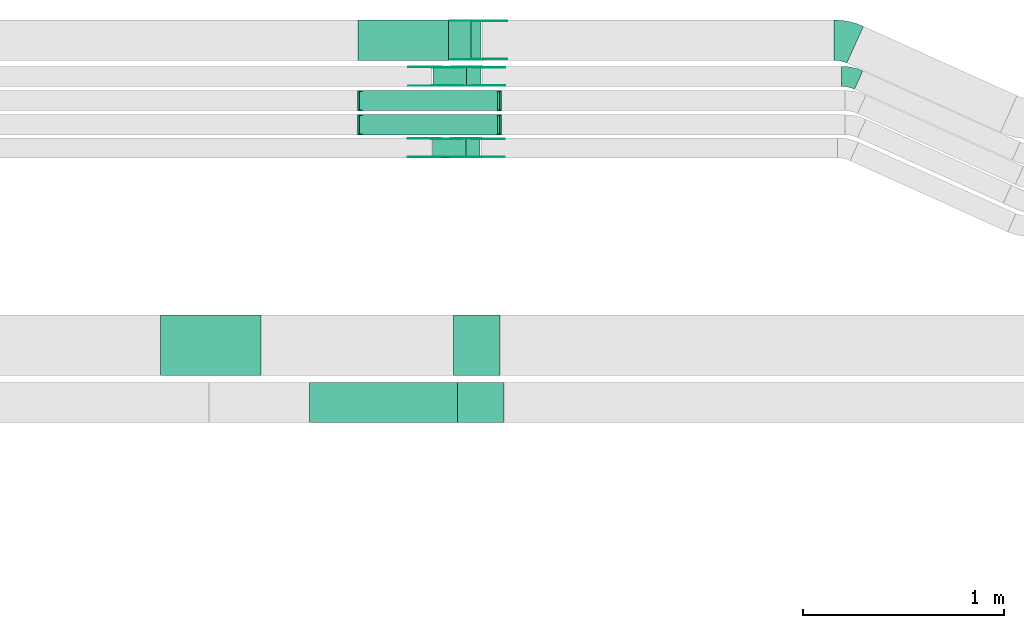
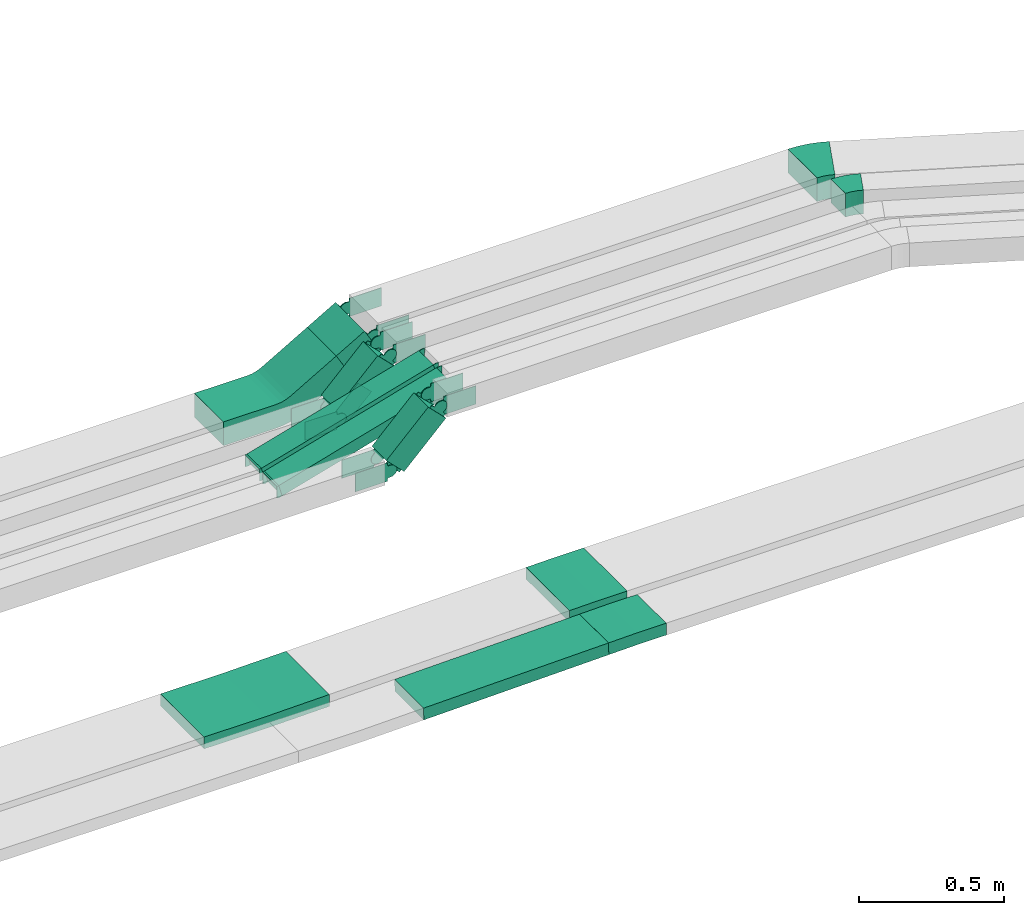
# One storey, part 11 of 28: 30 flow fittings, 6 flow segments.
"""IFC2X3 building model written with IfcOpenShell, lengths in millimetres."""

import ifcopenshell
import ifcopenshell.guid

model = None  # the IFC model being written
_history = None  # IfcOwnerHistory: only IFC2X3 demands one
_inside = {}  # id of a spatial element -> (the spatial element, [elements in it])
_under = {}  # id of a project, library or spatial element -> (it, [spatial elements below it])
_declared = {}  # id of a project -> (the project, [libraries it declares])
_typed = {}  # id of a type object -> (the type object, [elements of that type])
_made_of = {}  # id of a material, layer set ... -> (it, [elements and type objects made of it])


def new_model(schema):
    """Start an empty IFC model of exactly this schema.

    Asked for "IFC4X3", IfcOpenShell would pick the latest addendum, in which some entities
    have other attributes; the version numbers below select the first issue.
    IFC2X3 requires an IfcOwnerHistory on every rooted entity: one is made here for all.
    """
    global model, _history
    if schema == "IFC4X3":
        model = ifcopenshell.file(schema_version=(4, 3, 0, 0))
    else:
        model = ifcopenshell.file(schema=schema)
    _inside.clear()
    _under.clear()
    _declared.clear()
    _typed.clear()
    _made_of.clear()
    _history = None
    if model.schema == "IFC2X3":
        org = make("IfcOrganization", Name="unknown")
        user = make(
            "IfcPersonAndOrganization",
            ThePerson=make("IfcPerson", FamilyName="unknown"),
            TheOrganization=org,
        )
        app = make(
            "IfcApplication",
            ApplicationDeveloper=org,
            Version="unknown",
            ApplicationFullName="unknown",
            ApplicationIdentifier="unknown",
        )
        _history = make(
            "IfcOwnerHistory",
            OwningUser=user,
            OwningApplication=app,
            ChangeAction="ADDED",
            CreationDate=0,
        )
    return model


def make(cls, **values):
    """One entity of the class cls with the attributes given. An attribute that is None is left unset."""
    return model.create_entity(
        cls, **{name: value for name, value in values.items() if value is not None}
    )


def entity(cls, *values):
    """Any entity or typed value of the class cls, its attributes in the order of the schema. None: left unset."""
    e = model.create_entity(cls)
    for i, value in enumerate(values):
        if value is not None:
            e[i] = value
    return e


def rooted(cls, **values):
    """An entity with a GlobalId (a new one), such as an element, a storey or a relation."""
    return make(cls, GlobalId=ifcopenshell.guid.new(), OwnerHistory=_history, **values)


def si_unit(unit_type, name, prefix=None):
    """IfcSIUnit, for example si_unit("LENGTHUNIT", "METRE", prefix="MILLI")."""
    return make("IfcSIUnit", UnitType=unit_type, Prefix=prefix, Name=name)


def converted_unit(unit_type, name, factor, base, dimensions=None, offset=None):
    """IfcConversionBasedUnit, such as the inch: factor (a typed value) times the base unit."""
    return make(
        "IfcConversionBasedUnit"
        if offset is None
        else "IfcConversionBasedUnitWithOffset",
        ConversionOffset=offset,
        Dimensions=None
        if dimensions is None
        else entity("IfcDimensionalExponents", *dimensions),
        UnitType=unit_type,
        Name=name,
        ConversionFactor=make(
            "IfcMeasureWithUnit", ValueComponent=factor, UnitComponent=base
        ),
    )


def derived_unit(unit_type, elements):
    """IfcDerivedUnit: a product of units, each with its exponent."""
    return make(
        "IfcDerivedUnit",
        Elements=[
            make("IfcDerivedUnitElement", Unit=unit, Exponent=power)
            for unit, power in elements
        ],
        UnitType=unit_type,
    )


def assignment(units):
    """IfcUnitAssignment: the units of a project."""
    return None if units is None else make("IfcUnitAssignment", Units=units)


def point(xyz):
    """IfcCartesianPoint."""
    return None if xyz is None else make("IfcCartesianPoint", Coordinates=xyz)


def direction(xyz):
    """IfcDirection."""
    return None if xyz is None else make("IfcDirection", DirectionRatios=xyz)


def frame(location, z_axis=None, x_axis=None):
    """IfcAxis2Placement3D, a coordinate frame: its origin and axes. An axis left out is left unset."""
    return make(
        "IfcAxis2Placement3D",
        Location=point(location),
        Axis=direction(z_axis),
        RefDirection=direction(x_axis),
    )


def frame_2d(location, x_axis=None):
    """IfcAxis2Placement2D, a coordinate frame in the plane: its origin and x axis."""
    return make(
        "IfcAxis2Placement2D", Location=point(location), RefDirection=direction(x_axis)
    )


def origin():
    """The frame at (0, 0, 0) with its axes left unset."""
    return frame((0.0, 0.0, 0.0))


def origin_2d_with_axis():
    """The frame at (0, 0) in the plane with the x axis (1, 0) written out."""
    return frame_2d((0.0, 0.0), x_axis=(1.0, 0.0))


def place(relative_to, where):
    """IfcLocalPlacement: puts the frame where relative to a parent placement (None: the world)."""
    return make(
        "IfcLocalPlacement", PlacementRelTo=relative_to, RelativePlacement=where
    )


def context(
    kind, dimensions, precision=None, world=None, true_north=None, identifier=None
):
    """IfcGeometricRepresentationContext, for example the 3D "Model" context."""
    return make(
        "IfcGeometricRepresentationContext",
        ContextIdentifier=identifier,
        ContextType=kind,
        CoordinateSpaceDimension=dimensions,
        Precision=precision,
        WorldCoordinateSystem=world,
        TrueNorth=true_north,
    )


def subcontext(parent, identifier, kind, view, scale=None):
    """IfcGeometricRepresentationSubContext, for example "Body" below "Model"."""
    return make(
        "IfcGeometricRepresentationSubContext",
        ContextIdentifier=identifier,
        ContextType=kind,
        ParentContext=parent,
        TargetScale=scale,
        TargetView=view,
    )


def project(units=None, contexts=None):
    """IfcProject with its units and contexts."""
    return rooted(
        "IfcProject",
        Name="project",
        RepresentationContexts=contexts,
        UnitsInContext=assignment(units),
    )


def spatial(cls, under=None, at=None, **own):
    """A site, building, storey or space (cls), placed at a placement, below another one or the project."""
    s = rooted(cls, ObjectPlacement=at, **own)
    if under is not None:
        _under.setdefault(under.id(), (under, []))[1].append(s)
    return s


def polyline(points):
    """IfcPolyline through the points."""
    return make("IfcPolyline", Points=[point(p) for p in points])


def circle_curve(where, radius):
    """IfcCircle in the frame where."""
    return make("IfcCircle", Position=where, Radius=radius)


def parameter(value):
    """IfcParameterValue: where a trimmed curve begins or ends, as a parameter of its basis curve."""
    return model.create_entity("IfcParameterValue", value)


def trimmed(basis, trim1, trim2, sense, master):
    """IfcTrimmedCurve: the piece of a basis curve between two trims."""
    return make(
        "IfcTrimmedCurve",
        BasisCurve=basis,
        Trim1=trim1,
        Trim2=trim2,
        SenseAgreement=sense,
        MasterRepresentation=master,
    )


def segment(curve, same_sense, transition):
    """IfcCompositeCurveSegment."""
    return make(
        "IfcCompositeCurveSegment",
        Transition=transition,
        SameSense=same_sense,
        ParentCurve=curve,
    )


def composite_curve(segments, self_intersect=None):
    """IfcCompositeCurve: segments joined end to end."""
    return make("IfcCompositeCurve", Segments=segments, SelfIntersect=self_intersect)


def profile(cls, at=None, kind="AREA", **sizes):
    """A parametric profile (cls). Its sizes go by their IFC names, for example OverallWidth=200.0."""
    return make(cls, ProfileType=kind, Position=at, **sizes)


def rectangle(**sizes):
    """IfcRectangleProfileDef."""
    return profile("IfcRectangleProfileDef", **sizes)


def outline(outer, holes=None, kind="AREA"):
    """IfcArbitraryClosedProfileDef: a profile drawn as a closed curve; with holes, ...WithVoids."""
    if holes is None:
        return make("IfcArbitraryClosedProfileDef", ProfileType=kind, OuterCurve=outer)
    return make(
        "IfcArbitraryProfileDefWithVoids",
        ProfileType=kind,
        OuterCurve=outer,
        InnerCurves=holes,
    )


def extrude(swept, where, along, depth):
    """IfcExtrudedAreaSolid: the profile swept, set in the frame where, extruded along a direction by depth."""
    return make(
        "IfcExtrudedAreaSolid",
        SweptArea=swept,
        Position=where,
        ExtrudedDirection=direction(along),
        Depth=depth,
    )


def faces_of(points, faces, orient=None, outer=None):
    """IfcFace entities. A face is a list of loops; a loop is a list of indices into points, from 0.

    orient and outer hold one flag for each loop. By default every Orientation is true, the
    first loop of a face is its IfcFaceOuterBound and the others are IfcFaceBound.
    """
    made = []
    for i, loops in enumerate(faces):
        bounds = []
        for j, loop in enumerate(loops):
            is_outer = j == 0 if outer is None else outer[i][j]
            bounds.append(
                make(
                    "IfcFaceOuterBound" if is_outer else "IfcFaceBound",
                    Bound=make("IfcPolyLoop", Polygon=[points[k] for k in loop]),
                    Orientation=True if orient is None else orient[i][j],
                )
            )
        made.append(make("IfcFace", Bounds=bounds))
    return made


def faceted_brep(points, faces, orient=None, outer=None, voids=None):
    """IfcFacetedBrep: a solid bounded by flat faces; with voids (closed shells), ...WithVoids."""
    shared = [point(p) for p in points]
    hull = make("IfcClosedShell", CfsFaces=faces_of(shared, faces, orient, outer))
    if voids is None:
        return make("IfcFacetedBrep", Outer=hull)
    return make(
        "IfcFacetedBrepWithVoids",
        Outer=hull,
        Voids=[
            make(cls, CfsFaces=faces_of(shared, fs, o, b)) for cls, fs, o, b in voids
        ],
    )


def shape(context_of_items, identifier, shape_type, items):
    """IfcShapeRepresentation: the items that make up one representation, for example the "Body"."""
    return make(
        "IfcShapeRepresentation",
        ContextOfItems=context_of_items,
        RepresentationIdentifier=identifier,
        RepresentationType=shape_type,
        Items=items,
    )


def source(mapping_origin, context_of_items, identifier, shape_type, items):
    """IfcRepresentationMap: a shape defined once, which mapped items show again and again."""
    return make(
        "IfcRepresentationMap",
        MappingOrigin=mapping_origin,
        MappedRepresentation=shape(context_of_items, identifier, shape_type, items),
    )


def transform(
    local_origin,
    x_axis=None,
    y_axis=None,
    z_axis=None,
    scale=None,
    scale2=None,
    scale3=None,
    uniform=True,
):
    """IfcCartesianTransformationOperator3D, or its non-uniform kind. x_axis, y_axis, z_axis: its Axis1, 2, 3."""
    if uniform:
        return make(
            "IfcCartesianTransformationOperator3D",
            Axis1=direction(x_axis),
            Axis2=direction(y_axis),
            LocalOrigin=point(local_origin),
            Scale=scale,
            Axis3=direction(z_axis),
        )
    return make(
        "IfcCartesianTransformationOperator3DnonUniform",
        Axis1=direction(x_axis),
        Axis2=direction(y_axis),
        LocalOrigin=point(local_origin),
        Scale=scale,
        Axis3=direction(z_axis),
        Scale2=scale2,
        Scale3=scale3,
    )


def mapped(mapping_source, mapping_target):
    """IfcMappedItem: shows the shape of a source again, moved by a transform."""
    return make(
        "IfcMappedItem", MappingSource=mapping_source, MappingTarget=mapping_target
    )


def material(Name=None, Category=None):
    """IfcMaterial."""
    return make("IfcMaterial", Name=Name, Category=Category)


def made_of(thing, what):
    """Note that an element or type object is made of a material, layer set ...; save() writes the relation."""
    if what is not None:
        _made_of.setdefault(what.id(), (what, []))[1].append(thing)
    return thing


def type_object(cls, material=None, **own):
    """A type object (cls), such as IfcWallType, which elements share."""
    return made_of(rooted(cls, **own), material)


def type_shapes(of_type, sources):
    """Give a type object the sources (RepresentationMaps) that its elements show as mapped items."""
    of_type.RepresentationMaps = sources


def element(
    cls,
    number,
    at=None,
    inside=None,
    cuts=None,
    type_object=None,
    material=None,
    context=None,
    identifier="Body",
    shape_type=None,
    held_by="IfcProductDefinitionShape",
    body=None,
    shapes=None,
    **own,
):
    """One element of the class cls, such as IfcWall. Its Tag is "e" and its number.

    at: its placement. inside: the storey or other place that contains it. cuts: it is an
    opening in that element (IfcRelVoidsElement). A single representation is given by context,
    identifier, shape_type and body (its items); several are given by shapes. held_by: the class
    of the entity that holds the representations. save() writes the other relations.
    """
    e = rooted(cls, Tag="e%d" % number, ObjectPlacement=at, **own)
    if body is not None:
        shapes = [shape(context, identifier, shape_type, body)]
    if shapes is not None:
        e.Representation = make(held_by, Representations=shapes)
    if inside is not None:
        _inside.setdefault(inside.id(), (inside, []))[1].append(e)
    if cuts is not None:
        rooted(
            "IfcRelVoidsElement", RelatingBuildingElement=cuts, RelatedOpeningElement=e
        )
    if type_object is not None:
        _typed.setdefault(type_object.id(), (type_object, []))[1].append(e)
    return made_of(e, material)


def aggregate(whole, parts):
    """IfcRelAggregates: a whole, such as a stair, and the parts it consists of."""
    return rooted("IfcRelAggregates", RelatingObject=whole, RelatedObjects=parts)


def save(model, path):
    """Write the relations noted so far, then the file.

    IfcRelAggregates (storeys below a building ...), IfcRelContainedInSpatialStructure (elements
    in a storey), IfcRelDefinesByType, IfcRelAssociatesMaterial and IfcRelDeclares: one each for
    every whole, place, type object, material and project.
    """
    for whole, parts in _under.values():
        aggregate(whole, parts)
    for where, things in _inside.values():
        rooted(
            "IfcRelContainedInSpatialStructure",
            RelatedElements=things,
            RelatingStructure=where,
        )
    for kind, things in _typed.values():
        rooted("IfcRelDefinesByType", RelatedObjects=things, RelatingType=kind)
    for what, things in _made_of.values():
        rooted("IfcRelAssociatesMaterial", RelatedObjects=things, RelatingMaterial=what)
    for by, libraries in _declared.values():
        rooted("IfcRelDeclares", RelatingContext=by, RelatedDefinitions=libraries)
    model.write(path)


model = new_model("IFC2X3")

# Units and contexts
model_context = context("Model", 3, precision=0.01, world=origin(), true_north=direction((6.12303176911189e-17, 1.0)))
body_context = subcontext(model_context, "Body", "Model", "MODEL_VIEW")
ifc_project = project(units=[si_unit("LENGTHUNIT", "METRE", prefix="MILLI"), si_unit("AREAUNIT", "SQUARE_METRE"), si_unit("VOLUMEUNIT", "CUBIC_METRE"), converted_unit("PLANEANGLEUNIT", "DEGREE", entity("IfcRatioMeasure", 0.0174532925199433), si_unit("PLANEANGLEUNIT", "RADIAN"), dimensions=[0, 0, 0, 0, 0, 0, 0]), si_unit("MASSUNIT", "GRAM", prefix="KILO"), derived_unit("MASSDENSITYUNIT", [(si_unit("MASSUNIT", "GRAM", prefix="KILO"), 1), (si_unit("LENGTHUNIT", "METRE"), -3)]), derived_unit("MOMENTOFINERTIAUNIT", [(si_unit("LENGTHUNIT", "METRE"), 4)]), si_unit("TIMEUNIT", "SECOND"), si_unit("FREQUENCYUNIT", "HERTZ"), si_unit("THERMODYNAMICTEMPERATUREUNIT", "DEGREE_CELSIUS"), derived_unit("THERMALTRANSMITTANCEUNIT", [(si_unit("MASSUNIT", "GRAM", prefix="KILO"), 1), (si_unit("THERMODYNAMICTEMPERATUREUNIT", "KELVIN"), -1), (si_unit("TIMEUNIT", "SECOND"), -3)]), derived_unit("VOLUMETRICFLOWRATEUNIT", [(si_unit("LENGTHUNIT", "METRE"), 3), (si_unit("TIMEUNIT", "SECOND"), -1)]), derived_unit("MASSFLOWRATEUNIT", [(si_unit("MASSUNIT", "GRAM", prefix="KILO"), 1), (si_unit("TIMEUNIT", "SECOND"), -1)]), derived_unit("ROTATIONALFREQUENCYUNIT", [(si_unit("TIMEUNIT", "SECOND"), -1)]), si_unit("ELECTRICCURRENTUNIT", "AMPERE"), si_unit("ELECTRICVOLTAGEUNIT", "VOLT"), si_unit("POWERUNIT", "WATT"), si_unit("FORCEUNIT", "NEWTON", prefix="KILO"), si_unit("ILLUMINANCEUNIT", "LUX"), si_unit("LUMINOUSFLUXUNIT", "LUMEN"), si_unit("LUMINOUSINTENSITYUNIT", "CANDELA"), derived_unit("USERDEFINED", [(si_unit("MASSUNIT", "GRAM", prefix="KILO"), -1), (si_unit("LENGTHUNIT", "METRE"), -2), (si_unit("TIMEUNIT", "SECOND"), 3), (si_unit("LUMINOUSFLUXUNIT", "LUMEN"), 1)]), derived_unit("LINEARVELOCITYUNIT", [(si_unit("LENGTHUNIT", "METRE"), 1), (si_unit("TIMEUNIT", "SECOND"), -1)]), si_unit("PRESSUREUNIT", "PASCAL"), derived_unit("USERDEFINED", [(si_unit("LENGTHUNIT", "METRE"), -2), (si_unit("MASSUNIT", "GRAM", prefix="KILO"), 1), (si_unit("TIMEUNIT", "SECOND"), -2)]), derived_unit("LINEARFORCEUNIT", [(si_unit("MASSUNIT", "GRAM", prefix="KILO"), 1), (si_unit("LENGTHUNIT", "METRE"), 1), (si_unit("TIMEUNIT", "SECOND"), -2), (si_unit("LENGTHUNIT", "METRE"), -1)]), derived_unit("PLANARFORCEUNIT", [(si_unit("MASSUNIT", "GRAM", prefix="KILO"), 1), (si_unit("LENGTHUNIT", "METRE"), 1), (si_unit("TIMEUNIT", "SECOND"), -2), (si_unit("LENGTHUNIT", "METRE"), -2)])], contexts=[model_context])

# Site, building, storey
site_placement = place(None, origin())
site = spatial("IfcSite", under=ifc_project, at=site_placement, CompositionType="ELEMENT")
building_placement = place(site_placement, origin())
building = spatial("IfcBuilding", under=site, at=building_placement, CompositionType="ELEMENT")
storey_placement = place(building_placement, frame((0.0, 0.0, 15900.0)))
storey = spatial("IfcBuildingStorey", under=building, at=storey_placement, CompositionType="ELEMENT", Elevation=15900.0)

# Flow segments
cable_carrier_segment_type = type_object("IfcCableCarrierSegmentType", PredefinedType="CABLETRAYSEGMENT")
flow_segment_1_placement = place(storey_placement, frame((34281.5, 15999.99, 2768.97)))
element("IfcFlowSegment", 1, at=flow_segment_1_placement, inside=storey, type_object=cable_carrier_segment_type, context=body_context, shape_type="SweptSolid", body=[
    extrude(rectangle(XDim=99.9999999999999, YDim=129.97901079922, at=frame_2d((0.0, 0.0), x_axis=(0.0, 1.0))), frame((81.28, 0.0, 75.8), z_axis=(0.0, 1.0, 0.0), x_axis=(-0.866025403784409, 0.0, -0.500000000000051)), (0.0, 0.0, 1.0), 200.000000000004),
])
flow_segment_2_placement = place(storey_placement, frame((34204.49, 15869.99, 2666.17)))
element("IfcFlowSegment", 2, at=flow_segment_2_placement, inside=storey, type_object=cable_carrier_segment_type, context=body_context, shape_type="SweptSolid", body=[
    extrude(rectangle(XDim=100.000000000004, YDim=99.9999999999989, at=origin_2d_with_axis()), frame((35.36, 50.0, 35.36), z_axis=(0.707106781186461, 0.0, 0.707106781186634), x_axis=(-0.707106781186634, 0.0, 0.707106781186461)), (0.0, 0.0, 1.0), 236.107647738385),
])
flow_segment_3_placement = place(storey_placement, frame((34200.93, 15514.99, 2666.17)))
element("IfcFlowSegment", 3, at=flow_segment_3_placement, inside=storey, type_object=cable_carrier_segment_type, context=body_context, shape_type="SweptSolid", body=[
    extrude(rectangle(XDim=100.000000000002, YDim=99.9999999999989, at=origin_2d_with_axis()), frame((35.36, 50.0, 35.36), z_axis=(0.70710678118645, 0.0, 0.707106781186645), x_axis=(-0.707106781186645, 0.0, 0.70710678118645)), (0.0, 0.0, 1.0), 236.046602434653),
])
flow_segment_4_placement = place(storey_placement, frame((33838.37, 15629.46, 2641.19)))
element("IfcFlowSegment", 4, at=flow_segment_4_placement, inside=storey, type_object=cable_carrier_segment_type, context=body_context, shape_type="SweptSolid", body=[
    extrude(rectangle(XDim=49.9999999999985, YDim=99.9999999999989, at=origin_2d_with_axis()), frame((6.87, 50.0, 24.04), z_axis=(0.96152394764081, 0.0, 0.274721127897424), x_axis=(-0.274721127897424, 0.0, 0.96152394764081)), (0.0, 0.0, 1.0), 712.892453597831),
])
flow_segment_5_placement = place(storey_placement, frame((33838.37, 15749.46, 2641.19)))
element("IfcFlowSegment", 5, at=flow_segment_5_placement, inside=storey, type_object=cable_carrier_segment_type, context=body_context, shape_type="SweptSolid", body=[
    extrude(rectangle(XDim=49.9999999999985, YDim=99.9999999999989, at=origin_2d_with_axis()), frame((6.87, 50.0, 24.04), z_axis=(0.96152394764081, 0.0, 0.274721127897424), x_axis=(-0.274721127897424, 0.0, 0.96152394764081)), (0.0, 0.0, 1.0), 712.892453597741),
])
flow_segment_6_placement = place(storey_placement, frame((33590.04, 14200.03, 2655.67)))
element("IfcFlowSegment", 6, at=flow_segment_6_placement, inside=storey, type_object=cable_carrier_segment_type, context=body_context, shape_type="SweptSolid", body=[
    extrude(rectangle(XDim=50.0000000000022, YDim=199.999999999998, at=origin_2d_with_axis()), frame((0.57, 100.0, 24.99), z_axis=(0.999742430409444, 0.0, 0.0226952162144029), x_axis=(-0.0226952162144029, 0.0, 0.999742430409444)), (0.0, 0.0, 1.0), 737.074167716574),
])

# Flow fittings
ifc_material_1 = material()
cable_carrier_fitting_type_1 = type_object("IfcCableCarrierFittingType", PredefinedType="NOTDEFINED", material=ifc_material_1)
shared_shape_1 = source(origin(), body_context, "Body", "Brep", [
    faceted_brep([(-7.0, 25.0, 50.0), (-7.0, 25.0, -50.0), (-7.0, -25.0, -50.0), (-7.0, -25.0, -47.46), (-7.0, 22.46, -47.46), (-7.0, 22.46, 47.46), (-7.0, -25.0, 47.46), (-7.0, -25.0, 50.0), (-0.13, 25.96, 50.0), (13.6, -22.11, 50.0), (13.6, -22.11, 47.46), (0.56, 23.52, 47.46), (0.56, 23.52, -47.46), (13.6, -22.11, -47.46), (13.6, -22.11, -50.0), (-0.13, 25.96, -50.0), (-3.5, 25.0, 50.0), (-3.5, 25.0, -50.0), (3.5, -25.0, -50.0), (3.5, -25.0, -47.46), (-3.15, 22.46, -47.46), (-3.15, 22.46, 47.46), (3.5, -25.0, 47.46), (3.5, -25.0, 50.0)], [[[0, 1, 2, 3, 4, 5, 6, 7]], [[8, 9, 10, 11, 12, 13, 14, 15]], [[1, 0, 16, 17]], [[2, 1, 17, 15, 14, 18]], [[3, 2, 18, 19]], [[4, 3, 19, 13, 12, 20]], [[5, 4, 20, 21]], [[6, 5, 21, 11, 10, 22]], [[7, 6, 22, 23]], [[0, 7, 23, 9, 8, 16]], [[17, 16, 8, 15]], [[19, 18, 14, 13]], [[21, 20, 12, 11]], [[23, 22, 10, 9]]]),
])
type_shapes(cable_carrier_fitting_type_1, [shared_shape_1])
for number, where, z_axis, x_axis in (
    (7, (34537.44, 15799.46, 2863.0), (0.0, 1.0, 0.0), (0.961523947640807, 0.0, 0.274721127897435)),
    (8, (34537.44, 15679.46, 2863.0), (0.0, 1.0, 0.0), (0.961523947640807, 0.0, 0.274721127897435)),
    (9, (33838.51, 15799.46, 2663.31), (0.0, 1.0, 0.0), (-0.961523947640821, 0.0, -0.274721127897387)),
    (10, (33838.51, 15679.46, 2663.31), (0.0, 1.0, 0.0), (-0.961523947640823, 0.0, -0.274721127897379)),
):
    element("IfcFlowFitting", number, at=place(storey_placement, frame(where, z_axis=z_axis, x_axis=x_axis)), inside=storey, type_object=cable_carrier_fitting_type_1, material=ifc_material_1, context=body_context, shape_type="MappedRepresentation", body=[
        mapped(shared_shape_1, transform((0.0, 0.0, 0.0), scale=1.0)),
    ])
ifc_material_2 = material(Name="G")
cable_carrier_fitting_type_2 = type_object("IfcCableCarrierFittingType", PredefinedType="NOTDEFINED", material=ifc_material_2)
shared_shape_2 = source(origin(), body_context, "Body", "SweptSolid", [
    extrude(outline(composite_curve([segment(trimmed(circle_curve(frame_2d((-41.47, 0.0), x_axis=(1.0, 0.0)), 25.0), [parameter(90.0000000000007)], [parameter(270.0)], True, "PARAMETER"), True, "CONTINUOUS"), segment(polyline([(-41.47, -25.0), (-29.97, -25.0)]), True, "CONTINUOUS"), segment(polyline([(-29.97, -25.0), (-28.1, -38.5)]), True, "CONTINUOUS"), segment(polyline([(-28.1, -38.5), (99.53, -38.5)]), True, "CONTINUOUS"), segment(polyline([(99.53, -38.5), (99.53, 38.5)]), True, "CONTINUOUS"), segment(polyline([(99.53, 38.5), (-28.1, 38.5)]), True, "CONTINUOUS"), segment(polyline([(-28.1, 38.5), (-29.97, 25.0)]), True, "CONTINUOUS"), segment(polyline([(-29.97, 25.0), (-41.47, 25.0)]), True, "CONTINUOUS")], self_intersect=False)), frame((41.47, 0.0, 0.0), z_axis=(0.0, 0.0, -1.0), x_axis=(1.0, 0.0, 0.0)), (0.0, 0.0, -1.0), 2.0),
])
type_shapes(cable_carrier_fitting_type_2, [shared_shape_2])
flow_fitting_1_placement = place(storey_placement, frame((34423.32, 15874.53, 2885.0), z_axis=(0.0, -1.0, 0.0), x_axis=(-0.707106781186429, 0.0, -0.707106781186666)))
element("IfcFlowFitting", 11, at=flow_fitting_1_placement, inside=storey, type_object=cable_carrier_fitting_type_2, material=ifc_material_2, context=body_context, shape_type="MappedRepresentation", body=[
    mapped(shared_shape_2, transform((0.0, 0.0, 0.0), scale=1.0)),
])
cable_carrier_fitting_type_3 = type_object("IfcCableCarrierFittingType", PredefinedType="NOTDEFINED", material=ifc_material_2)
type_shapes(cable_carrier_fitting_type_3, [shared_shape_2])
flow_fitting_2_placement = place(storey_placement, frame((34423.32, 15963.45, 2885.0), z_axis=(0.0, 1.0, 0.0), x_axis=(1.0, 0.0, 0.0)))
element("IfcFlowFitting", 12, at=flow_fitting_2_placement, inside=storey, type_object=cable_carrier_fitting_type_3, material=ifc_material_2, context=body_context, shape_type="MappedRepresentation", body=[
    mapped(shared_shape_2, transform((0.0, 0.0, 0.0), scale=1.0)),
])
flow_fitting_3_placement = place(storey_placement, frame((34419.71, 15519.53, 2884.96), z_axis=(0.0, -1.0, 0.0), x_axis=(-0.707106781186429, 0.0, -0.707106781186666)))
element("IfcFlowFitting", 13, at=flow_fitting_3_placement, inside=storey, type_object=cable_carrier_fitting_type_2, material=ifc_material_2, context=body_context, shape_type="MappedRepresentation", body=[
    mapped(shared_shape_2, transform((0.0, 0.0, 0.0), scale=1.0)),
])
flow_fitting_4_placement = place(storey_placement, frame((34419.71, 15608.45, 2884.96), z_axis=(0.0, 1.0, 0.0), x_axis=(1.0, 0.0, 0.0)))
element("IfcFlowFitting", 14, at=flow_fitting_4_placement, inside=storey, type_object=cable_carrier_fitting_type_3, material=ifc_material_2, context=body_context, shape_type="MappedRepresentation", body=[
    mapped(shared_shape_2, transform((0.0, 0.0, 0.0), scale=1.0)),
])
flow_fitting_5_placement = place(storey_placement, frame((34223.32, 15965.45, 2685.0), z_axis=(0.0, 1.0, 0.0), x_axis=(-1.0, 0.0, 0.0)))
element("IfcFlowFitting", 15, at=flow_fitting_5_placement, inside=storey, type_object=cable_carrier_fitting_type_2, material=ifc_material_2, context=body_context, shape_type="MappedRepresentation", body=[
    mapped(shared_shape_2, transform((0.0, 0.0, 0.0), scale=1.0)),
])
flow_fitting_6_placement = place(storey_placement, frame((34223.32, 15876.53, 2685.0), z_axis=(0.0, -1.0, 0.0), x_axis=(0.707106781186433, 0.0, 0.707106781186662)))
element("IfcFlowFitting", 16, at=flow_fitting_6_placement, inside=storey, type_object=cable_carrier_fitting_type_3, material=ifc_material_2, context=body_context, shape_type="MappedRepresentation", body=[
    mapped(shared_shape_2, transform((0.0, 0.0, 0.0), scale=1.0)),
])
flow_fitting_7_placement = place(storey_placement, frame((34219.76, 15610.45, 2685.0), z_axis=(0.0, 1.0, 0.0), x_axis=(-1.0, 0.0, 0.0)))
element("IfcFlowFitting", 17, at=flow_fitting_7_placement, inside=storey, type_object=cable_carrier_fitting_type_2, material=ifc_material_2, context=body_context, shape_type="MappedRepresentation", body=[
    mapped(shared_shape_2, transform((0.0, 0.0, 0.0), scale=1.0)),
])
flow_fitting_8_placement = place(storey_placement, frame((34219.76, 15521.53, 2685.0), z_axis=(0.0, -1.0, 0.0), x_axis=(0.707106781186413, 0.0, 0.707106781186682)))
element("IfcFlowFitting", 18, at=flow_fitting_8_placement, inside=storey, type_object=cable_carrier_fitting_type_3, material=ifc_material_2, context=body_context, shape_type="MappedRepresentation", body=[
    mapped(shared_shape_2, transform((0.0, 0.0, 0.0), scale=1.0)),
])
flow_fitting_9_placement = place(storey_placement, frame((34432.46, 16004.53, 2885.0), z_axis=(0.0, -1.0, 0.0), x_axis=(-0.866025403784327, 0.0, -0.500000000000193)))
element("IfcFlowFitting", 19, at=flow_fitting_9_placement, inside=storey, type_object=cable_carrier_fitting_type_2, material=ifc_material_2, context=body_context, shape_type="MappedRepresentation", body=[
    mapped(shared_shape_2, transform((0.0, 0.0, 0.0), scale=1.0)),
])
flow_fitting_10_placement = place(storey_placement, frame((34432.46, 16193.45, 2885.0), z_axis=(0.0, 1.0, 0.0), x_axis=(1.0, 0.0, 0.0)))
element("IfcFlowFitting", 20, at=flow_fitting_10_placement, inside=storey, type_object=cable_carrier_fitting_type_3, material=ifc_material_2, context=body_context, shape_type="MappedRepresentation", body=[
    mapped(shared_shape_2, transform((0.0, 0.0, 0.0), scale=1.0)),
])
cable_carrier_fitting_type_4 = type_object("IfcCableCarrierFittingType", PredefinedType="NOTDEFINED", material=ifc_material_2)
shared_shape_3 = source(origin(), body_context, "Body", "SweptSolid", [
    extrude(outline(composite_curve([segment(trimmed(circle_curve(frame_2d((-41.47, 0.0), x_axis=(1.0, 0.0)), 25.0), [parameter(90.0000000000007)], [parameter(270.0)], True, "PARAMETER"), True, "CONTINUOUS"), segment(polyline([(-41.47, -25.0), (-29.97, -25.0)]), True, "CONTINUOUS"), segment(polyline([(-29.97, -25.0), (-28.1, -38.5)]), True, "CONTINUOUS"), segment(polyline([(-28.1, -38.5), (99.53, -38.5)]), True, "CONTINUOUS"), segment(polyline([(99.53, -38.5), (99.53, 38.5)]), True, "CONTINUOUS"), segment(polyline([(99.53, 38.5), (-28.1, 38.5)]), True, "CONTINUOUS"), segment(polyline([(-28.1, 38.5), (-29.97, 25.0)]), True, "CONTINUOUS"), segment(polyline([(-29.97, 25.0), (-41.47, 25.0)]), True, "CONTINUOUS")], self_intersect=False)), frame((41.47, 0.0, 0.0)), (0.0, 0.0, 1.0), 2.0),
])
type_shapes(cable_carrier_fitting_type_4, [shared_shape_3])
flow_fitting_11_placement = place(storey_placement, frame((34423.32, 15965.45, 2885.0), z_axis=(0.0, 1.0, 0.0), x_axis=(-0.707106781186429, 0.0, -0.707106781186666)))
element("IfcFlowFitting", 21, at=flow_fitting_11_placement, inside=storey, type_object=cable_carrier_fitting_type_4, material=ifc_material_2, context=body_context, shape_type="MappedRepresentation", body=[
    mapped(shared_shape_3, transform((0.0, 0.0, 0.0), scale=1.0)),
])
cable_carrier_fitting_type_5 = type_object("IfcCableCarrierFittingType", PredefinedType="NOTDEFINED", material=ifc_material_2)
type_shapes(cable_carrier_fitting_type_5, [shared_shape_3])
flow_fitting_12_placement = place(storey_placement, frame((34423.32, 15876.53, 2885.0), z_axis=(0.0, -1.0, 0.0), x_axis=(1.0, 0.0, 0.0)))
element("IfcFlowFitting", 22, at=flow_fitting_12_placement, inside=storey, type_object=cable_carrier_fitting_type_5, material=ifc_material_2, context=body_context, shape_type="MappedRepresentation", body=[
    mapped(shared_shape_3, transform((0.0, 0.0, 0.0), scale=1.0)),
])
flow_fitting_13_placement = place(storey_placement, frame((34419.71, 15610.45, 2884.96), z_axis=(0.0, 1.0, 0.0), x_axis=(-0.707106781186429, 0.0, -0.707106781186666)))
element("IfcFlowFitting", 23, at=flow_fitting_13_placement, inside=storey, type_object=cable_carrier_fitting_type_4, material=ifc_material_2, context=body_context, shape_type="MappedRepresentation", body=[
    mapped(shared_shape_3, transform((0.0, 0.0, 0.0), scale=1.0)),
])
flow_fitting_14_placement = place(storey_placement, frame((34419.71, 15521.53, 2884.96), z_axis=(0.0, -1.0, 0.0), x_axis=(1.0, 0.0, 0.0)))
element("IfcFlowFitting", 24, at=flow_fitting_14_placement, inside=storey, type_object=cable_carrier_fitting_type_5, material=ifc_material_2, context=body_context, shape_type="MappedRepresentation", body=[
    mapped(shared_shape_3, transform((0.0, 0.0, 0.0), scale=1.0)),
])
flow_fitting_15_placement = place(storey_placement, frame((34223.32, 15874.53, 2685.0), z_axis=(0.0, -1.0, 0.0), x_axis=(-1.0, 0.0, 0.0)))
element("IfcFlowFitting", 25, at=flow_fitting_15_placement, inside=storey, type_object=cable_carrier_fitting_type_4, material=ifc_material_2, context=body_context, shape_type="MappedRepresentation", body=[
    mapped(shared_shape_3, transform((0.0, 0.0, 0.0), scale=1.0)),
])
flow_fitting_16_placement = place(storey_placement, frame((34223.32, 15963.45, 2685.0), z_axis=(0.0, 1.0, 0.0), x_axis=(0.707106781186433, 0.0, 0.707106781186662)))
element("IfcFlowFitting", 26, at=flow_fitting_16_placement, inside=storey, type_object=cable_carrier_fitting_type_5, material=ifc_material_2, context=body_context, shape_type="MappedRepresentation", body=[
    mapped(shared_shape_3, transform((0.0, 0.0, 0.0), scale=1.0)),
])
flow_fitting_17_placement = place(storey_placement, frame((34219.76, 15519.53, 2685.0), z_axis=(0.0, -1.0, 0.0), x_axis=(-1.0, 0.0, 0.0)))
element("IfcFlowFitting", 27, at=flow_fitting_17_placement, inside=storey, type_object=cable_carrier_fitting_type_4, material=ifc_material_2, context=body_context, shape_type="MappedRepresentation", body=[
    mapped(shared_shape_3, transform((0.0, 0.0, 0.0), scale=1.0)),
])
flow_fitting_18_placement = place(storey_placement, frame((34219.76, 15608.45, 2685.0), z_axis=(0.0, 1.0, 0.0), x_axis=(0.707106781186413, 0.0, 0.707106781186682)))
element("IfcFlowFitting", 28, at=flow_fitting_18_placement, inside=storey, type_object=cable_carrier_fitting_type_5, material=ifc_material_2, context=body_context, shape_type="MappedRepresentation", body=[
    mapped(shared_shape_3, transform((0.0, 0.0, 0.0), scale=1.0)),
])
flow_fitting_19_placement = place(storey_placement, frame((34432.46, 16195.45, 2885.0), z_axis=(0.0, 1.0, 0.0), x_axis=(-0.866025403784327, 0.0, -0.500000000000193)))
element("IfcFlowFitting", 29, at=flow_fitting_19_placement, inside=storey, type_object=cable_carrier_fitting_type_4, material=ifc_material_2, context=body_context, shape_type="MappedRepresentation", body=[
    mapped(shared_shape_3, transform((0.0, 0.0, 0.0), scale=1.0)),
])
flow_fitting_20_placement = place(storey_placement, frame((34432.46, 16006.53, 2885.0), z_axis=(0.0, -1.0, 0.0), x_axis=(1.0, 0.0, 0.0)))
element("IfcFlowFitting", 30, at=flow_fitting_20_placement, inside=storey, type_object=cable_carrier_fitting_type_5, material=ifc_material_2, context=body_context, shape_type="MappedRepresentation", body=[
    mapped(shared_shape_3, transform((0.0, 0.0, 0.0), scale=1.0)),
])
cable_carrier_fitting_type_6 = type_object("IfcCableCarrierFittingType", Name="470_DKC_S5_CS 90 internal vertical angle:-", PredefinedType="NOTDEFINED", material=ifc_material_1)
shared_shape_4 = source(origin(), body_context, "Body", "SweptSolid", [
    extrude(outline(composite_curve([segment(polyline([(-244.55, -87.35), (-34.2, -87.35)]), True, "CONTINUOUS"), segment(trimmed(circle_curve(frame_2d((-34.2, 127.65), x_axis=(0.0, -1.0)), 214.999999999999), [parameter(0.0)], [parameter(29.9999999999997)], True, "PARAMETER"), True, "CONTINUOUS"), segment(polyline([(73.3, -58.54), (255.45, 46.63)]), True, "CONTINUOUS"), segment(polyline([(255.45, 46.63), (205.45, 133.23)]), True, "CONTINUOUS"), segment(polyline([(205.45, 133.23), (23.3, 28.06)]), True, "CONTINUOUS"), segment(trimmed(circle_curve(frame_2d((-34.2, 127.65), x_axis=(0.0, -1.0)), 114.999999999999), [parameter(0.0)], [parameter(29.9999999999997)], True, "PARAMETER"), False, "CONTINUOUS"), segment(polyline([(-34.2, 12.65), (-244.55, 12.65)]), True, "CONTINUOUS"), segment(polyline([(-244.55, 12.65), (-244.55, -87.35)]), True, "CONTINUOUS")], self_intersect=False)), frame((-10.01, 37.35, -100.0)), (0.0, 0.0, 1.0), 200.0),
])
type_shapes(cable_carrier_fitting_type_6, [shared_shape_4])
flow_fitting_21_placement = place(storey_placement, frame((34086.05, 16099.99, 2685.0), z_axis=(0.0, 1.0, 0.0), x_axis=(-0.866025403784432, 0.0, -0.500000000000012)))
element("IfcFlowFitting", 31, at=flow_fitting_21_placement, inside=storey, type_object=cable_carrier_fitting_type_6, material=ifc_material_1, Name="470_DKC_S5_CS 90 internal vertical angle:-", ObjectType="470_DKC_S5_CS 90 internal vertical angle:-", context=body_context, shape_type="MappedRepresentation", body=[
    mapped(shared_shape_4, transform((0.0, 0.0, 0.0), scale=1.0)),
])
cable_carrier_fitting_type_7 = type_object("IfcCableCarrierFittingType", Name="470_DKC_S5_CD 90 external vertical angle:-", PredefinedType="NOTDEFINED", material=ifc_material_1)
shared_shape_5 = source(origin(), body_context, "Body", "SweptSolid", [
    extrude(outline(composite_curve([segment(polyline([(-114.72, -25.66), (-1.87, -25.66)]), True, "CONTINUOUS"), segment(trimmed(circle_curve(frame_2d((-1.87, 164.34), x_axis=(0.0, -1.0)), 189.999999999999), [parameter(0.0)], [parameter(1.30045175841151)], True, "PARAMETER"), True, "CONTINUOUS"), segment(polyline([(2.45, -25.61), (115.28, -23.05)]), True, "CONTINUOUS"), segment(polyline([(115.28, -23.05), (114.14, 26.94)]), True, "CONTINUOUS"), segment(polyline([(114.14, 26.94), (1.31, 24.37)]), True, "CONTINUOUS"), segment(trimmed(circle_curve(frame_2d((-1.87, 164.34), x_axis=(0.0, -1.0)), 139.999999999999), [parameter(0.0)], [parameter(1.30045175841151)], True, "PARAMETER"), False, "CONTINUOUS"), segment(polyline([(-1.87, 24.34), (-114.72, 24.34)]), True, "CONTINUOUS"), segment(polyline([(-114.72, 24.34), (-114.72, -25.66)]), True, "CONTINUOUS")], self_intersect=False)), frame((-0.01, 0.66, -100.0)), (0.0, 0.0, 1.0), 200.0),
])
type_shapes(cable_carrier_fitting_type_7, [shared_shape_5])
flow_fitting_22_placement = place(storey_placement, frame((34442.19, 14300.03, 2700.0), z_axis=(0.0, -1.0, 0.0), x_axis=(-1.0, 0.0, 0.0)))
element("IfcFlowFitting", 32, at=flow_fitting_22_placement, inside=storey, type_object=cable_carrier_fitting_type_7, material=ifc_material_1, Name="470_DKC_S5_CD 90 external vertical angle:-", ObjectType="470_DKC_S5_CD 90 external vertical angle:-", context=body_context, shape_type="MappedRepresentation", body=[
    mapped(shared_shape_5, transform((0.0, 0.0, 0.0), scale=1.0)),
])
cable_carrier_fitting_type_8 = type_object("IfcCableCarrierFittingType", Name="470_DKC_S5_CD 90 external vertical angle:-", PredefinedType="NOTDEFINED", material=ifc_material_1)
shared_shape_6 = source(origin(), body_context, "Body", "SweptSolid", [
    extrude(outline(composite_curve([segment(polyline([(-114.77, -25.55), (-1.56, -25.55)]), True, "CONTINUOUS"), segment(trimmed(circle_curve(frame_2d((-1.56, 164.45), x_axis=(0.0, -1.0)), 189.999999999999), [parameter(0.0)], [parameter(1.08397495340498)], True, "PARAMETER"), True, "CONTINUOUS"), segment(polyline([(2.04, -25.52), (115.23, -23.37)]), True, "CONTINUOUS"), segment(polyline([(115.23, -23.37), (114.29, 26.62)]), True, "CONTINUOUS"), segment(polyline([(114.29, 26.62), (1.09, 24.47)]), True, "CONTINUOUS"), segment(trimmed(circle_curve(frame_2d((-1.56, 164.45), x_axis=(0.0, -1.0)), 139.999999999999), [parameter(0.0)], [parameter(1.08397495340498)], True, "PARAMETER"), False, "CONTINUOUS"), segment(polyline([(-1.56, 24.45), (-114.77, 24.45)]), True, "CONTINUOUS"), segment(polyline([(-114.77, 24.45), (-114.77, -25.55)]), True, "CONTINUOUS")], self_intersect=False)), frame((-0.01, 0.55, -150.0)), (0.0, 0.0, 1.0), 300.0),
])
type_shapes(cable_carrier_fitting_type_8, [shared_shape_6])
flow_fitting_23_placement = place(storey_placement, frame((34422.19, 14585.03, 2700.0), z_axis=(0.0, -1.0, 0.0), x_axis=(-1.0, 0.0, 0.0)))
element("IfcFlowFitting", 33, at=flow_fitting_23_placement, inside=storey, type_object=cable_carrier_fitting_type_8, material=ifc_material_1, Name="470_DKC_S5_CD 90 external vertical angle:-", ObjectType="470_DKC_S5_CD 90 external vertical angle:-", context=body_context, shape_type="MappedRepresentation", body=[
    mapped(shared_shape_6, transform((0.0, 0.0, 0.0), scale=1.0)),
])
cable_carrier_fitting_type_9 = type_object("IfcCableCarrierFittingType", Name="470_DKC_S5_Variable Angle Elbow 0-45:-", PredefinedType="NOTDEFINED", material=ifc_material_1)
shared_shape_7 = source(origin(), body_context, "Body", "SweptSolid", [
    extrude(outline(composite_curve([segment(polyline([(-52.45, -111.19), (-51.45, -111.19)]), True, "CONTINUOUS"), segment(trimmed(circle_curve(frame_2d((-51.45, 238.81), x_axis=(0.0, -1.0)), 350.0), [parameter(0.0)], [parameter(24.3183682159225)], True, "PARAMETER"), True, "CONTINUOUS"), segment(polyline([(92.68, -80.14), (93.59, -79.73)]), True, "CONTINUOUS"), segment(polyline([(93.59, -79.73), (11.23, 102.53)]), True, "CONTINUOUS"), segment(polyline([(11.23, 102.53), (10.32, 102.12)]), True, "CONTINUOUS"), segment(trimmed(circle_curve(frame_2d((-51.45, 238.81), x_axis=(0.0, -1.0)), 150.0), [parameter(0.0)], [parameter(24.3183682159225)], True, "PARAMETER"), False, "CONTINUOUS"), segment(polyline([(-51.45, 88.81), (-52.45, 88.81)]), True, "CONTINUOUS"), segment(polyline([(-52.45, 88.81), (-52.45, -111.19)]), True, "CONTINUOUS")], self_intersect=False)), frame((-2.41, 11.19, -50.0)), (0.0, 0.0, 1.0), 100.0),
])
type_shapes(cable_carrier_fitting_type_9, [shared_shape_7])
flow_fitting_24_placement = place(storey_placement, frame((36251.59, 16099.99, 2885.0), z_axis=(0.0, 0.0, 1.0), x_axis=(-0.911271304124221, 0.41180652044345, 0.0)))
element("IfcFlowFitting", 34, at=flow_fitting_24_placement, inside=storey, type_object=cable_carrier_fitting_type_9, material=ifc_material_1, Name="470_DKC_S5_Variable Angle Elbow 0-45:-", ObjectType="470_DKC_S5_Variable Angle Elbow 0-45:-", context=body_context, shape_type="MappedRepresentation", body=[
    mapped(shared_shape_7, transform((0.0, 0.0, 0.0), scale=1.0)),
])
cable_carrier_fitting_type_10 = type_object("IfcCableCarrierFittingType", Name="470_DKC_S5_Variable Angle Elbow 0-45:-", PredefinedType="NOTDEFINED", material=ifc_material_1)
shared_shape_8 = source(origin(), body_context, "Body", "SweptSolid", [
    extrude(outline(composite_curve([segment(polyline([(-42.16, -58.98), (-41.16, -58.98)]), True, "CONTINUOUS"), segment(trimmed(circle_curve(frame_2d((-41.16, 191.02), x_axis=(0.0, -1.0)), 250.0), [parameter(0.0)], [parameter(24.3183682159238)], True, "PARAMETER"), True, "CONTINUOUS"), segment(polyline([(61.79, -36.79), (62.7, -36.38)]), True, "CONTINUOUS"), segment(polyline([(62.7, -36.38), (21.52, 54.75)]), True, "CONTINUOUS"), segment(polyline([(21.52, 54.75), (20.61, 54.33)]), True, "CONTINUOUS"), segment(trimmed(circle_curve(frame_2d((-41.16, 191.02), x_axis=(0.0, -1.0)), 150.0), [parameter(0.0)], [parameter(24.3183682159238)], True, "PARAMETER"), False, "CONTINUOUS"), segment(polyline([(-41.16, 41.02), (-42.16, 41.02)]), True, "CONTINUOUS"), segment(polyline([(-42.16, 41.02), (-42.16, -58.98)]), True, "CONTINUOUS")], self_intersect=False)), frame((-1.93, 8.98, -50.0)), (0.0, 0.0, 1.0), 100.0),
])
type_shapes(cable_carrier_fitting_type_10, [shared_shape_8])
flow_fitting_25_placement = place(storey_placement, frame((36279.02, 15919.99, 2885.0), z_axis=(0.0, 0.0, 1.0), x_axis=(-0.911271304124207, 0.411806520443481, 0.0)))
element("IfcFlowFitting", 35, at=flow_fitting_25_placement, inside=storey, type_object=cable_carrier_fitting_type_10, material=ifc_material_1, Name="470_DKC_S5_Variable Angle Elbow 0-45:-", ObjectType="470_DKC_S5_Variable Angle Elbow 0-45:-", context=body_context, shape_type="MappedRepresentation", body=[
    mapped(shared_shape_8, transform((0.0, 0.0, 0.0), scale=1.0)),
])
cable_carrier_fitting_type_11 = type_object("IfcCableCarrierFittingType", Name="470_DKC_S5_CS 90 internal vertical angle:-", PredefinedType="NOTDEFINED", material=ifc_material_1)
shared_shape_9 = source(origin(), body_context, "Body", "SweptSolid", [
    extrude(outline(composite_curve([segment(polyline([(-249.77, -26.19), (-1.31, -26.19)]), True, "CONTINUOUS"), segment(trimmed(circle_curve(frame_2d((-1.31, 138.81), x_axis=(0.0, -1.0)), 164.999999999999), [parameter(0.0)], [parameter(1.08397495340462)], True, "PARAMETER"), True, "CONTINUOUS"), segment(polyline([(1.81, -26.16), (250.23, -21.46)]), True, "CONTINUOUS"), segment(polyline([(250.23, -21.46), (249.28, 28.53)]), True, "CONTINUOUS"), segment(polyline([(249.28, 28.53), (0.86, 23.83)]), True, "CONTINUOUS"), segment(trimmed(circle_curve(frame_2d((-1.31, 138.81), x_axis=(0.0, -1.0)), 114.999999999999), [parameter(0.0)], [parameter(1.08397495340462)], True, "PARAMETER"), False, "CONTINUOUS"), segment(polyline([(-1.31, 23.81), (-249.77, 23.81)]), True, "CONTINUOUS"), segment(polyline([(-249.77, 23.81), (-249.77, -26.19)]), True, "CONTINUOUS")], self_intersect=False)), frame((-0.01, 1.19, -150.0)), (0.0, 0.0, 1.0), 300.0),
])
type_shapes(cable_carrier_fitting_type_11, [shared_shape_9])
flow_fitting_26_placement = place(storey_placement, frame((33100.92, 14585.03, 2675.0), z_axis=(0.0, 1.0, 0.0), x_axis=(-0.999821042344905, 0.0, -0.0189178033700457)))
element("IfcFlowFitting", 36, at=flow_fitting_26_placement, inside=storey, type_object=cable_carrier_fitting_type_11, material=ifc_material_1, Name="470_DKC_S5_CS 90 internal vertical angle:-", ObjectType="470_DKC_S5_CS 90 internal vertical angle:-", context=body_context, shape_type="MappedRepresentation", body=[
    mapped(shared_shape_9, transform((0.0, 0.0, 0.0), scale=1.0)),
])

save(model, "model.ifc")
